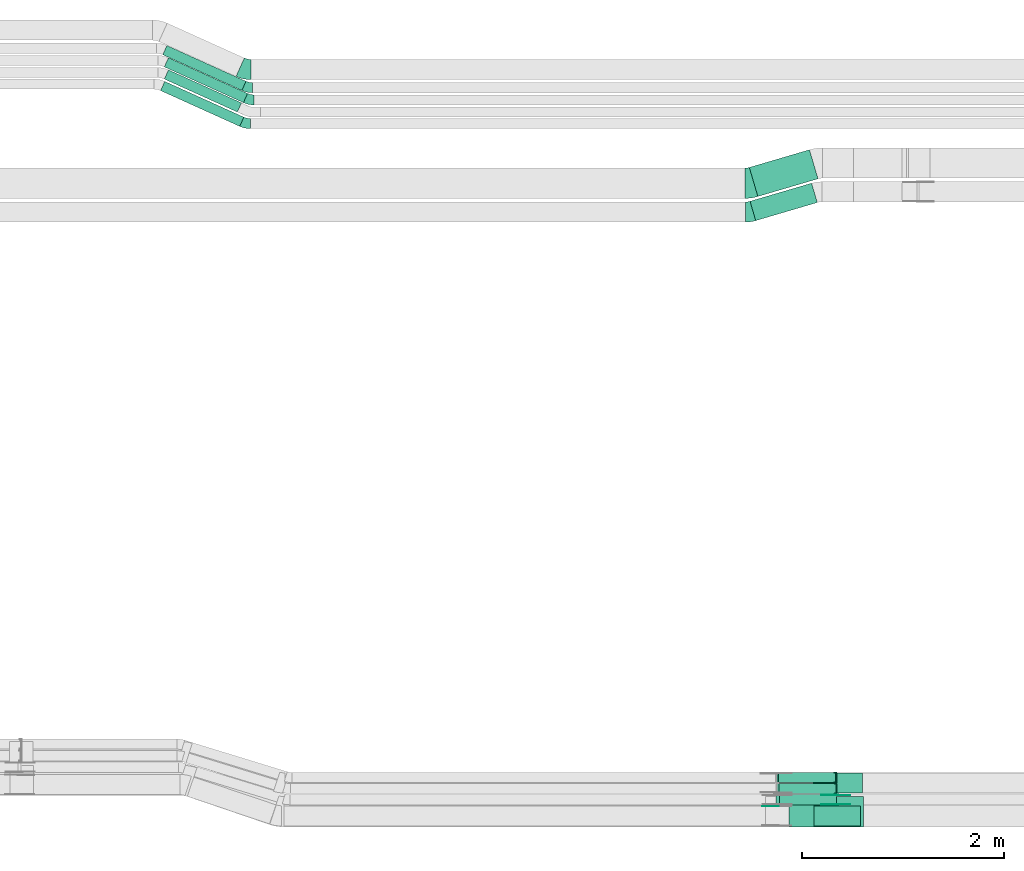
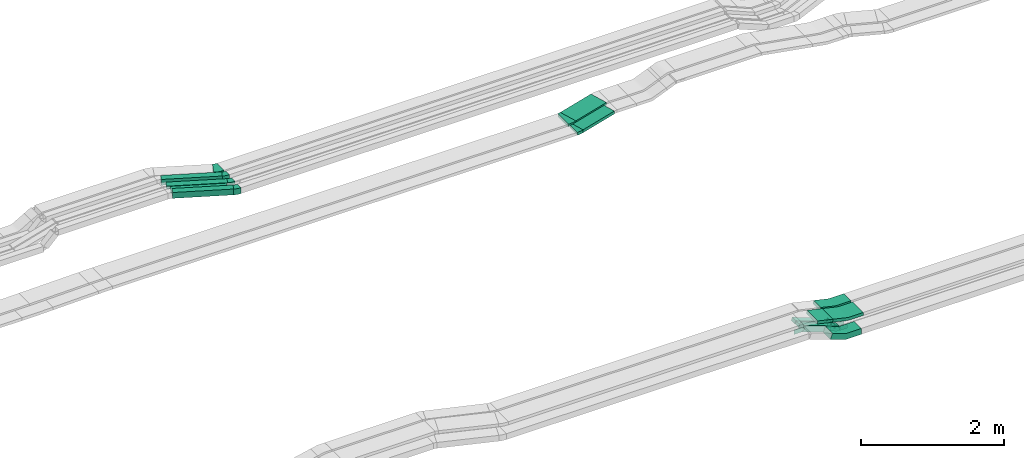
# One storey, part 13 of 28: 16 flow fittings, 10 flow segments.
"""IFC2X3 building model written with IfcOpenShell, lengths in millimetres."""

from ifc_helpers import new_model, entity, si_unit, converted_unit, derived_unit, direction, frame, frame_2d, origin, origin_2d_with_axis, place, context, subcontext, project, spatial, polyline, circle_curve, parameter, trimmed, segment, composite_curve, rectangle, outline, extrude, faceted_brep, source, transform, mapped, material, type_object, type_shapes, element, save


model = new_model("IFC2X3")

# Units and contexts
model_context = context("Model", 3, precision=0.01, world=origin(), true_north=direction((6.12303176911189e-17, 1.0)))
body_context = subcontext(model_context, "Body", "Model", "MODEL_VIEW")
ifc_project = project(units=[si_unit("LENGTHUNIT", "METRE", prefix="MILLI"), si_unit("AREAUNIT", "SQUARE_METRE"), si_unit("VOLUMEUNIT", "CUBIC_METRE"), converted_unit("PLANEANGLEUNIT", "DEGREE", entity("IfcRatioMeasure", 0.0174532925199433), si_unit("PLANEANGLEUNIT", "RADIAN"), dimensions=[0, 0, 0, 0, 0, 0, 0]), si_unit("MASSUNIT", "GRAM", prefix="KILO"), derived_unit("MASSDENSITYUNIT", [(si_unit("MASSUNIT", "GRAM", prefix="KILO"), 1), (si_unit("LENGTHUNIT", "METRE"), -3)]), derived_unit("MOMENTOFINERTIAUNIT", [(si_unit("LENGTHUNIT", "METRE"), 4)]), si_unit("TIMEUNIT", "SECOND"), si_unit("FREQUENCYUNIT", "HERTZ"), si_unit("THERMODYNAMICTEMPERATUREUNIT", "DEGREE_CELSIUS"), derived_unit("THERMALTRANSMITTANCEUNIT", [(si_unit("MASSUNIT", "GRAM", prefix="KILO"), 1), (si_unit("THERMODYNAMICTEMPERATUREUNIT", "KELVIN"), -1), (si_unit("TIMEUNIT", "SECOND"), -3)]), derived_unit("VOLUMETRICFLOWRATEUNIT", [(si_unit("LENGTHUNIT", "METRE"), 3), (si_unit("TIMEUNIT", "SECOND"), -1)]), derived_unit("MASSFLOWRATEUNIT", [(si_unit("MASSUNIT", "GRAM", prefix="KILO"), 1), (si_unit("TIMEUNIT", "SECOND"), -1)]), derived_unit("ROTATIONALFREQUENCYUNIT", [(si_unit("TIMEUNIT", "SECOND"), -1)]), si_unit("ELECTRICCURRENTUNIT", "AMPERE"), si_unit("ELECTRICVOLTAGEUNIT", "VOLT"), si_unit("POWERUNIT", "WATT"), si_unit("FORCEUNIT", "NEWTON", prefix="KILO"), si_unit("ILLUMINANCEUNIT", "LUX"), si_unit("LUMINOUSFLUXUNIT", "LUMEN"), si_unit("LUMINOUSINTENSITYUNIT", "CANDELA"), derived_unit("USERDEFINED", [(si_unit("MASSUNIT", "GRAM", prefix="KILO"), -1), (si_unit("LENGTHUNIT", "METRE"), -2), (si_unit("TIMEUNIT", "SECOND"), 3), (si_unit("LUMINOUSFLUXUNIT", "LUMEN"), 1)]), derived_unit("LINEARVELOCITYUNIT", [(si_unit("LENGTHUNIT", "METRE"), 1), (si_unit("TIMEUNIT", "SECOND"), -1)]), si_unit("PRESSUREUNIT", "PASCAL"), derived_unit("USERDEFINED", [(si_unit("LENGTHUNIT", "METRE"), -2), (si_unit("MASSUNIT", "GRAM", prefix="KILO"), 1), (si_unit("TIMEUNIT", "SECOND"), -2)]), derived_unit("LINEARFORCEUNIT", [(si_unit("MASSUNIT", "GRAM", prefix="KILO"), 1), (si_unit("LENGTHUNIT", "METRE"), 1), (si_unit("TIMEUNIT", "SECOND"), -2), (si_unit("LENGTHUNIT", "METRE"), -1)]), derived_unit("PLANARFORCEUNIT", [(si_unit("MASSUNIT", "GRAM", prefix="KILO"), 1), (si_unit("LENGTHUNIT", "METRE"), 1), (si_unit("TIMEUNIT", "SECOND"), -2), (si_unit("LENGTHUNIT", "METRE"), -2)])], contexts=[model_context])

# Site, building, storey
site_placement = place(None, origin())
site = spatial("IfcSite", under=ifc_project, at=site_placement, CompositionType="ELEMENT")
building_placement = place(site_placement, origin())
building = spatial("IfcBuilding", under=site, at=building_placement, CompositionType="ELEMENT")
storey_placement = place(building_placement, frame((0.0, 0.0, 15900.0)))
storey = spatial("IfcBuildingStorey", under=building, at=storey_placement, CompositionType="ELEMENT", Elevation=15900.0)

# Flow segments
cable_carrier_segment_type = type_object("IfcCableCarrierSegmentType", PredefinedType="CABLETRAYSEGMENT")
flow_segment_1_placement = place(storey_placement, frame((42482.32, 8215.15, 2877.21)))
element("IfcFlowSegment", 1, at=flow_segment_1_placement, inside=storey, type_object=cable_carrier_segment_type, context=body_context, shape_type="SweptSolid", body=[
    extrude(rectangle(XDim=49.9999999999981, YDim=255.770491519839, at=frame_2d((0.0, 0.0), x_axis=(0.0, 1.0))), frame((130.23, 0.0, 53.24), z_axis=(0.0, 1.0, 0.0), x_axis=(-0.974157642890838, 0.0, 0.225869180716108)), (0.0, 0.0, 1.0), 299.999999999999),
])
flow_segment_2_placement = place(storey_placement, frame((42367.7, 8434.97, 2506.48)))
element("IfcFlowSegment", 2, at=flow_segment_2_placement, inside=storey, type_object=cable_carrier_segment_type, context=body_context, shape_type="SweptSolid", body=[
    extrude(rectangle(XDim=100.000000000003, YDim=99.9999999999989, at=origin_2d_with_axis()), frame((16.92, 50.0, 250.0), z_axis=(0.940975525862782, 0.0, -0.338474607211915), x_axis=(0.338474607211915, 0.0, 0.940975525862782)), (0.0, 0.0, 1.0), 599.59714334412),
])
flow_segment_3_placement = place(storey_placement, frame((42378.69, 8544.97, 2499.72)))
element("IfcFlowSegment", 3, at=flow_segment_3_placement, inside=storey, type_object=cable_carrier_segment_type, context=body_context, shape_type="SweptSolid", body=[
    extrude(rectangle(XDim=50.0000000000049, YDim=100.000000000001, at=origin_2d_with_axis()), frame((8.68, 50.0, 232.8), z_axis=(0.937730259547007, 0.0, -0.347364304916183), x_axis=(0.347364304916183, 0.0, 0.937730259547007)), (0.0, 0.0, 1.0), 602.697848083628),
])
flow_segment_4_placement = place(storey_placement, frame((42374.95, 8654.97, 2499.69)))
element("IfcFlowSegment", 4, at=flow_segment_4_placement, inside=storey, type_object=cable_carrier_segment_type, context=body_context, shape_type="SweptSolid", body=[
    extrude(rectangle(XDim=50.0000000000049, YDim=100.000000000001, at=origin_2d_with_axis()), frame((8.68, 50.0, 232.79), z_axis=(0.937730259547007, 0.0, -0.347364304916183), x_axis=(0.347364304916183, 0.0, 0.937730259547007)), (0.0, 0.0, 1.0), 602.685608875145),
])
flow_segment_5_placement = place(storey_placement, frame((42109.48, 14214.53, 2675.0)))
element("IfcFlowSegment", 5, at=flow_segment_5_placement, inside=storey, type_object=cable_carrier_segment_type, context=body_context, shape_type="SweptSolid", body=[
    extrude(rectangle(XDim=634.797291199822, YDim=200.0, at=origin_2d_with_axis()), frame((332.72, 185.5, 0.0), z_axis=(0.0, 0.0, 1.0), x_axis=(-0.959365501571262, -0.282166323991578, 0.0)), (0.0, 0.0, 1.0), 50.0000000000016),
])
flow_segment_6_placement = place(storey_placement, frame((42102.28, 14453.59, 2675.0)))
element("IfcFlowSegment", 6, at=flow_segment_6_placement, inside=storey, type_object=cable_carrier_segment_type, context=body_context, shape_type="SweptSolid", body=[
    extrude(rectangle(XDim=620.396388266396, YDim=299.999999999998, at=origin_2d_with_axis()), frame((339.92, 231.43, 0.0), z_axis=(0.0, 0.0, 1.0), x_axis=(0.959365501571253, 0.28216632399161, 0.0)), (0.0, 0.0, 1.0), 50.0000000000016),
])
flow_segment_7_placement = place(storey_placement, frame((36298.61, 15502.59, 2835.0)))
element("IfcFlowSegment", 7, at=flow_segment_7_placement, inside=storey, type_object=cable_carrier_segment_type, context=body_context, shape_type="SweptSolid", body=[
    extrude(rectangle(XDim=858.861846645775, YDim=100.000000000002, at=origin_2d_with_axis()), frame((411.92, 222.41, 0.0), z_axis=(0.0, 0.0, 1.0), x_axis=(-0.911271304124208, 0.411806520443479, 0.0)), (0.0, 0.0, 1.0), 99.9999999999989),
])
flow_segment_8_placement = place(storey_placement, frame((36314.03, 15382.05, 2838.0)))
element("IfcFlowSegment", 8, at=flow_segment_8_placement, inside=storey, type_object=cable_carrier_segment_type, context=body_context, shape_type="SweptSolid", body=[
    extrude(rectangle(XDim=858.861846645806, YDim=100.000000000002, at=origin_2d_with_axis()), frame((411.92, 222.41, 0.0), z_axis=(0.0, 0.0, 1.0), x_axis=(-0.911271304124206, 0.411806520443484, 0.0)), (0.0, 0.0, 1.0), 50.0000000000016),
])
flow_segment_9_placement = place(storey_placement, frame((36314.03, 15289.01, 2838.0)))
element("IfcFlowSegment", 9, at=flow_segment_9_placement, inside=storey, type_object=cable_carrier_segment_type, context=body_context, shape_type="SweptSolid", body=[
    extrude(rectangle(XDim=793.388620361837, YDim=100.000000000002, at=origin_2d_with_axis()), frame((382.09, 208.92, 0.0), z_axis=(0.0, 0.0, 1.0), x_axis=(-0.911271304124207, 0.411806520443482, 0.0)), (0.0, 0.0, 1.0), 50.0000000000016),
])
flow_segment_10_placement = place(storey_placement, frame((36277.03, 15147.59, 2834.95)))
element("IfcFlowSegment", 10, at=flow_segment_10_placement, inside=storey, type_object=cable_carrier_segment_type, context=body_context, shape_type="SweptSolid", body=[
    extrude(rectangle(XDim=858.861846434138, YDim=99.9999999996995, at=origin_2d_with_axis()), frame((411.92, 222.41, 0.0), z_axis=(2.23645322951858e-06, -1.01066062150145e-06, 1.0), x_axis=(-0.911271304121465, 0.411806520442236, 2.45421228496595e-06)), (0.0, 0.0, 1.0), 99.999999999698),
])

# Flow fittings
ifc_material_1 = material()
cable_carrier_fitting_type_1 = type_object("IfcCableCarrierFittingType", PredefinedType="NOTDEFINED", material=ifc_material_1)
shared_shape_1 = source(origin(), body_context, "Body", "Brep", [
    faceted_brep([(-8.96, 25.0, 50.0), (-8.96, 25.0, -50.0), (-8.96, -25.0, -50.0), (-8.96, -25.0, -47.46), (-8.96, 22.46, -47.46), (-8.96, 22.46, 47.46), (-8.96, -25.0, 47.46), (-8.96, -25.0, 50.0), (-0.28, 26.56, 50.0), (17.09, -20.33, 50.0), (17.09, -20.33, 47.46), (0.6, 24.17, 47.46), (0.6, 24.17, -47.46), (17.09, -20.33, -47.46), (17.09, -20.33, -50.0), (-0.28, 26.56, -50.0), (-4.48, 25.0, 50.0), (-4.48, 25.0, -50.0), (4.48, -25.0, -50.0), (4.48, -25.0, -47.46), (-4.03, 22.46, -47.46), (-4.03, 22.46, 47.46), (4.48, -25.0, 47.46), (4.48, -25.0, 50.0)], [[[0, 1, 2, 3, 4, 5, 6, 7]], [[8, 9, 10, 11, 12, 13, 14, 15]], [[1, 0, 16, 17]], [[2, 1, 17, 15, 14, 18]], [[3, 2, 18, 19]], [[4, 3, 19, 13, 12, 20]], [[5, 4, 20, 21]], [[6, 5, 21, 11, 10, 22]], [[7, 6, 22, 23]], [[0, 7, 23, 9, 8, 16]], [[17, 16, 8, 15]], [[19, 18, 14, 13]], [[21, 20, 12, 11]], [[23, 22, 10, 9]]]),
])
type_shapes(cable_carrier_fitting_type_1, [shared_shape_1])
for number, where, z_axis, x_axis in (
    (11, (42960.95, 8594.97, 2520.05), (0.0, -1.0, 0.0), (0.937730259547021, 0.0, -0.347364304916146)),
    (12, (42957.2, 8704.97, 2520.02), (0.0, -1.0, 0.0), (0.937730259547021, 0.0, -0.347364304916146)),
):
    element("IfcFlowFitting", number, at=place(storey_placement, frame(where, z_axis=z_axis, x_axis=x_axis)), inside=storey, type_object=cable_carrier_fitting_type_1, material=ifc_material_1, context=body_context, shape_type="MappedRepresentation", body=[
        mapped(shared_shape_1, transform((0.0, 0.0, 0.0), scale=1.0)),
    ])
cable_carrier_fitting_type_2 = type_object("IfcCableCarrierFittingType", Name="470_DKC_S5_CS 90 internal vertical angle:-", PredefinedType="NOTDEFINED", material=ifc_material_1)
shared_shape_2 = source(origin(), body_context, "Body", "SweptSolid", [
    extrude(outline(composite_curve([segment(polyline([(-248.69, -40.04), (-14.3, -40.04)]), True, "CONTINUOUS"), segment(trimmed(circle_curve(frame_2d((-14.3, 124.96), x_axis=(0.0, -1.0)), 164.999999999999), [parameter(0.0)], [parameter(13.0539943692735)], True, "PARAMETER"), True, "CONTINUOUS"), segment(polyline([(22.97, -35.78), (251.31, 17.16)]), True, "CONTINUOUS"), segment(polyline([(251.31, 17.16), (240.02, 65.87)]), True, "CONTINUOUS"), segment(polyline([(240.02, 65.87), (11.68, 12.93)]), True, "CONTINUOUS"), segment(trimmed(circle_curve(frame_2d((-14.3, 124.96), x_axis=(0.0, -1.0)), 114.999999999999), [parameter(0.0)], [parameter(13.0539943692735)], True, "PARAMETER"), False, "CONTINUOUS"), segment(polyline([(-14.3, 9.96), (-248.69, 9.96)]), True, "CONTINUOUS"), segment(polyline([(-248.69, 9.96), (-248.69, -40.04)]), True, "CONTINUOUS")], self_intersect=False)), frame((-1.72, 15.04, -150.0)), (0.0, 0.0, 1.0), 300.0),
])
type_shapes(cable_carrier_fitting_type_2, [shared_shape_2])
flow_fitting_1_placement = place(storey_placement, frame((42981.07, 8365.15, 2845.0), z_axis=(0.0, 1.0, 0.0), x_axis=(-1.0, 0.0, 0.0)))
element("IfcFlowFitting", 13, at=flow_fitting_1_placement, inside=storey, type_object=cable_carrier_fitting_type_2, material=ifc_material_1, Name="470_DKC_S5_CS 90 internal vertical angle:-", ObjectType="470_DKC_S5_CS 90 internal vertical angle:-", context=body_context, shape_type="MappedRepresentation", body=[
    mapped(shared_shape_2, transform((0.0, 0.0, 0.0), scale=1.0)),
])
cable_carrier_fitting_type_3 = type_object("IfcCableCarrierFittingType", Name="470_DKC_S5_CS 90 internal vertical angle:-", PredefinedType="NOTDEFINED", material=ifc_material_1)
shared_shape_3 = source(origin(), body_context, "Body", "SweptSolid", [
    extrude(outline(composite_curve([segment(polyline([(-248.69, -40.04), (-14.3, -40.04)]), True, "CONTINUOUS"), segment(trimmed(circle_curve(frame_2d((-14.3, 124.96), x_axis=(0.0, -1.0)), 164.999999999999), [parameter(0.0)], [parameter(13.0539943692735)], True, "PARAMETER"), True, "CONTINUOUS"), segment(polyline([(22.97, -35.78), (251.31, 17.16)]), True, "CONTINUOUS"), segment(polyline([(251.31, 17.16), (240.02, 65.87)]), True, "CONTINUOUS"), segment(polyline([(240.02, 65.87), (11.68, 12.93)]), True, "CONTINUOUS"), segment(trimmed(circle_curve(frame_2d((-14.3, 124.96), x_axis=(0.0, -1.0)), 114.999999999999), [parameter(0.0)], [parameter(13.0539943692735)], True, "PARAMETER"), False, "CONTINUOUS"), segment(polyline([(-14.3, 9.96), (-248.69, 9.96)]), True, "CONTINUOUS"), segment(polyline([(-248.69, 9.96), (-248.69, -40.04)]), True, "CONTINUOUS")], self_intersect=False)), frame((-1.72, 15.04, -100.0)), (0.0, 0.0, 1.0), 200.0),
])
type_shapes(cable_carrier_fitting_type_3, [shared_shape_3])
flow_fitting_2_placement = place(storey_placement, frame((42971.26, 8650.15, 2845.0), z_axis=(0.0, 1.0, 0.0), x_axis=(-1.0, 0.0, 0.0)))
element("IfcFlowFitting", 14, at=flow_fitting_2_placement, inside=storey, type_object=cable_carrier_fitting_type_3, material=ifc_material_1, Name="470_DKC_S5_CS 90 internal vertical angle:-", ObjectType="470_DKC_S5_CS 90 internal vertical angle:-", context=body_context, shape_type="MappedRepresentation", body=[
    mapped(shared_shape_3, transform((0.0, 0.0, 0.0), scale=1.0)),
])
cable_carrier_fitting_type_4 = type_object("IfcCableCarrierFittingType", Name="470_DKC_S5_CS 90 internal vertical angle:-", PredefinedType="NOTDEFINED", material=ifc_material_1)
shared_shape_4 = source(origin(), body_context, "Body", "SweptSolid", [
    extrude(outline(composite_curve([segment(polyline([(-244.79, -73.49), (-24.68, -73.49)]), True, "CONTINUOUS"), segment(trimmed(circle_curve(frame_2d((-24.68, 141.51), x_axis=(0.0, -1.0)), 214.999999999999), [parameter(0.0)], [parameter(19.7839661238225)], True, "PARAMETER"), True, "CONTINUOUS"), segment(polyline([(48.1, -60.8), (255.21, 13.7)]), True, "CONTINUOUS"), segment(polyline([(255.21, 13.7), (221.37, 107.79)]), True, "CONTINUOUS"), segment(polyline([(221.37, 107.79), (14.25, 33.29)]), True, "CONTINUOUS"), segment(trimmed(circle_curve(frame_2d((-24.68, 141.51), x_axis=(0.0, -1.0)), 114.999999999999), [parameter(0.0)], [parameter(19.7839661238225)], True, "PARAMETER"), False, "CONTINUOUS"), segment(polyline([(-24.68, 26.51), (-244.79, 26.51)]), True, "CONTINUOUS"), segment(polyline([(-244.79, 26.51), (-244.79, -73.49)]), True, "CONTINUOUS")], self_intersect=False)), frame((-4.1, 23.49, -100.0)), (0.0, 0.0, 1.0), 200.0),
])
type_shapes(cable_carrier_fitting_type_4, [shared_shape_4])
flow_fitting_3_placement = place(storey_placement, frame((42954.58, 8324.97, 2550.0), z_axis=(0.0, -1.0, 0.0), x_axis=(0.940975525862787, 0.0, -0.338474607211903)))
element("IfcFlowFitting", 15, at=flow_fitting_3_placement, inside=storey, type_object=cable_carrier_fitting_type_4, material=ifc_material_1, Name="470_DKC_S5_CS 90 internal vertical angle:-", ObjectType="470_DKC_S5_CS 90 internal vertical angle:-", context=body_context, shape_type="MappedRepresentation", body=[
    mapped(shared_shape_4, transform((0.0, 0.0, 0.0), scale=1.0)),
])
ifc_material_2 = material(Name="G")
cable_carrier_fitting_type_5 = type_object("IfcCableCarrierFittingType", PredefinedType="NOTDEFINED", material=ifc_material_2)
shared_shape_5 = source(origin(), body_context, "Body", "SweptSolid", [
    extrude(outline(composite_curve([segment(trimmed(circle_curve(frame_2d((-41.47, 0.0), x_axis=(1.0, 0.0)), 25.0), [parameter(90.0000000000007)], [parameter(270.0)], True, "PARAMETER"), True, "CONTINUOUS"), segment(polyline([(-41.47, -25.0), (-29.97, -25.0)]), True, "CONTINUOUS"), segment(polyline([(-29.97, -25.0), (-28.1, -38.5)]), True, "CONTINUOUS"), segment(polyline([(-28.1, -38.5), (99.53, -38.5)]), True, "CONTINUOUS"), segment(polyline([(99.53, -38.5), (99.53, 38.5)]), True, "CONTINUOUS"), segment(polyline([(99.53, 38.5), (-28.1, 38.5)]), True, "CONTINUOUS"), segment(polyline([(-28.1, 38.5), (-29.97, 25.0)]), True, "CONTINUOUS"), segment(polyline([(-29.97, 25.0), (-41.47, 25.0)]), True, "CONTINUOUS")], self_intersect=False)), frame((41.47, 0.0, 0.0), z_axis=(0.0, 0.0, -1.0), x_axis=(1.0, 0.0, 0.0)), (0.0, 0.0, -1.0), 2.0),
])
type_shapes(cable_carrier_fitting_type_5, [shared_shape_5])
flow_fitting_4_placement = place(storey_placement, frame((42958.63, 8530.43, 2550.0), z_axis=(0.0, 1.0, 0.0), x_axis=(-0.940975525862779, 0.0, 0.338474607211925)))
element("IfcFlowFitting", 16, at=flow_fitting_4_placement, inside=storey, type_object=cable_carrier_fitting_type_5, material=ifc_material_2, context=body_context, shape_type="MappedRepresentation", body=[
    mapped(shared_shape_5, transform((0.0, 0.0, 0.0), scale=1.0)),
])
cable_carrier_fitting_type_6 = type_object("IfcCableCarrierFittingType", PredefinedType="NOTDEFINED", material=ifc_material_2)
type_shapes(cable_carrier_fitting_type_6, [shared_shape_5])
flow_fitting_5_placement = place(storey_placement, frame((42958.63, 8441.51, 2550.0), z_axis=(0.0, -1.0, 0.0), x_axis=(1.0, 0.0, 0.0)))
element("IfcFlowFitting", 17, at=flow_fitting_5_placement, inside=storey, type_object=cable_carrier_fitting_type_6, material=ifc_material_2, context=body_context, shape_type="MappedRepresentation", body=[
    mapped(shared_shape_5, transform((0.0, 0.0, 0.0), scale=1.0)),
])
cable_carrier_fitting_type_7 = type_object("IfcCableCarrierFittingType", PredefinedType="NOTDEFINED", material=ifc_material_2)
shared_shape_6 = source(origin(), body_context, "Body", "SweptSolid", [
    extrude(outline(composite_curve([segment(trimmed(circle_curve(frame_2d((-41.47, 0.0), x_axis=(1.0, 0.0)), 25.0), [parameter(90.0000000000007)], [parameter(270.0)], True, "PARAMETER"), True, "CONTINUOUS"), segment(polyline([(-41.47, -25.0), (-29.97, -25.0)]), True, "CONTINUOUS"), segment(polyline([(-29.97, -25.0), (-28.1, -38.5)]), True, "CONTINUOUS"), segment(polyline([(-28.1, -38.5), (99.53, -38.5)]), True, "CONTINUOUS"), segment(polyline([(99.53, -38.5), (99.53, 38.5)]), True, "CONTINUOUS"), segment(polyline([(99.53, 38.5), (-28.1, 38.5)]), True, "CONTINUOUS"), segment(polyline([(-28.1, 38.5), (-29.97, 25.0)]), True, "CONTINUOUS"), segment(polyline([(-29.97, 25.0), (-41.47, 25.0)]), True, "CONTINUOUS")], self_intersect=False)), frame((41.47, 0.0, 0.0)), (0.0, 0.0, 1.0), 2.0),
])
type_shapes(cable_carrier_fitting_type_7, [shared_shape_6])
flow_fitting_6_placement = place(storey_placement, frame((42958.63, 8439.51, 2550.0), z_axis=(0.0, -1.0, 0.0), x_axis=(-0.940975525862779, 0.0, 0.338474607211925)))
element("IfcFlowFitting", 18, at=flow_fitting_6_placement, inside=storey, type_object=cable_carrier_fitting_type_7, material=ifc_material_2, context=body_context, shape_type="MappedRepresentation", body=[
    mapped(shared_shape_6, transform((0.0, 0.0, 0.0), scale=1.0)),
])
cable_carrier_fitting_type_8 = type_object("IfcCableCarrierFittingType", PredefinedType="NOTDEFINED", material=ifc_material_2)
type_shapes(cable_carrier_fitting_type_8, [shared_shape_6])
for number, where, z_axis, x_axis in (
    (19, (42958.63, 8528.43, 2550.0), (0.0, 1.0, 0.0), (1.0, 0.0, 0.0)),
    (20, (42370.77, 8418.43, 2760.0), (0.0, 1.0, 0.0), (-1.0, 0.0, 0.0)),
):
    element("IfcFlowFitting", number, at=place(storey_placement, frame(where, z_axis=z_axis, x_axis=x_axis)), inside=storey, type_object=cable_carrier_fitting_type_8, material=ifc_material_2, context=body_context, shape_type="MappedRepresentation", body=[
        mapped(shared_shape_6, transform((0.0, 0.0, 0.0), scale=1.0)),
    ])
cable_carrier_fitting_type_9 = type_object("IfcCableCarrierFittingType", Name="470_DKC_S5_Variable Angle Elbow 0-45:-", PredefinedType="NOTDEFINED", material=ifc_material_1)
shared_shape_7 = source(origin(), body_context, "Body", "SweptSolid", [
    extrude(outline(composite_curve([segment(polyline([(-36.26, -105.15), (-35.26, -105.15)]), True, "CONTINUOUS"), segment(trimmed(circle_curve(frame_2d((-35.26, 244.85), x_axis=(0.0, -1.0)), 350.0), [parameter(0.0)], [parameter(16.3895403340349)], True, "PARAMETER"), True, "CONTINUOUS"), segment(polyline([(63.5, -90.93), (64.46, -90.65)]), True, "CONTINUOUS"), segment(polyline([(64.46, -90.65), (8.02, 101.23)]), True, "CONTINUOUS"), segment(polyline([(8.02, 101.23), (7.06, 100.95)]), True, "CONTINUOUS"), segment(trimmed(circle_curve(frame_2d((-35.26, 244.85), x_axis=(0.0, -1.0)), 150.0), [parameter(0.0)], [parameter(16.3895403340349)], True, "PARAMETER"), False, "CONTINUOUS"), segment(polyline([(-35.26, 94.85), (-36.26, 94.85)]), True, "CONTINUOUS"), segment(polyline([(-36.26, 94.85), (-36.26, -105.15)]), True, "CONTINUOUS")], self_intersect=False)), frame((-0.74, 5.15, -25.0)), (0.0, 0.0, 1.0), 50.0000000000005),
])
type_shapes(cable_carrier_fitting_type_9, [shared_shape_7])
flow_fitting_7_placement = place(storey_placement, frame((42102.19, 14300.03, 2700.0)))
element("IfcFlowFitting", 21, at=flow_fitting_7_placement, inside=storey, type_object=cable_carrier_fitting_type_9, material=ifc_material_1, Name="470_DKC_S5_Variable Angle Elbow 0-45:-", ObjectType="470_DKC_S5_Variable Angle Elbow 0-45:-", context=body_context, shape_type="MappedRepresentation", body=[
    mapped(shared_shape_7, transform((0.0, 0.0, 0.0), scale=1.0)),
])
cable_carrier_fitting_type_10 = type_object("IfcCableCarrierFittingType", Name="470_DKC_S5_Variable Angle Elbow 0-45:-", PredefinedType="NOTDEFINED", material=ifc_material_1)
shared_shape_8 = source(origin(), body_context, "Body", "SweptSolid", [
    extrude(outline(composite_curve([segment(polyline([(-43.31, -156.17), (-42.31, -156.17)]), True, "CONTINUOUS"), segment(trimmed(circle_curve(frame_2d((-42.31, 293.83), x_axis=(0.0, -1.0)), 450.0), [parameter(0.0)], [parameter(16.3895403340363)], True, "PARAMETER"), True, "CONTINUOUS"), segment(polyline([(84.66, -137.88), (85.62, -137.6)]), True, "CONTINUOUS"), segment(polyline([(85.62, -137.6), (0.97, 150.21)]), True, "CONTINUOUS"), segment(polyline([(0.97, 150.21), (0.01, 149.93)]), True, "CONTINUOUS"), segment(trimmed(circle_curve(frame_2d((-42.31, 293.83), x_axis=(0.0, -1.0)), 150.0), [parameter(0.0)], [parameter(16.3895403340363)], True, "PARAMETER"), False, "CONTINUOUS"), segment(polyline([(-42.31, 143.83), (-43.31, 143.83)]), True, "CONTINUOUS"), segment(polyline([(-43.31, 143.83), (-43.31, -156.17)]), True, "CONTINUOUS")], self_intersect=False)), frame((-0.89, 6.17, -25.0)), (0.0, 0.0, 1.0), 49.9999999999995),
])
type_shapes(cable_carrier_fitting_type_10, [shared_shape_8])
flow_fitting_8_placement = place(storey_placement, frame((42102.19, 14585.03, 2700.0)))
element("IfcFlowFitting", 22, at=flow_fitting_8_placement, inside=storey, type_object=cable_carrier_fitting_type_10, material=ifc_material_1, Name="470_DKC_S5_Variable Angle Elbow 0-45:-", ObjectType="470_DKC_S5_Variable Angle Elbow 0-45:-", context=body_context, shape_type="MappedRepresentation", body=[
    mapped(shared_shape_8, transform((0.0, 0.0, 0.0), scale=1.0)),
])
cable_carrier_fitting_type_11 = type_object("IfcCableCarrierFittingType", Name="470_DKC_S5_Variable Angle Elbow 0-45:-", PredefinedType="NOTDEFINED", material=ifc_material_1)
shared_shape_9 = source(origin(), body_context, "Body", "SweptSolid", [
    extrude(outline(composite_curve([segment(polyline([(-52.45, -111.19), (-51.45, -111.19)]), True, "CONTINUOUS"), segment(trimmed(circle_curve(frame_2d((-51.45, 238.81), x_axis=(0.0, -1.0)), 350.0), [parameter(0.0)], [parameter(24.3183682159225)], True, "PARAMETER"), True, "CONTINUOUS"), segment(polyline([(92.68, -80.14), (93.59, -79.73)]), True, "CONTINUOUS"), segment(polyline([(93.59, -79.73), (11.23, 102.53)]), True, "CONTINUOUS"), segment(polyline([(11.23, 102.53), (10.32, 102.12)]), True, "CONTINUOUS"), segment(trimmed(circle_curve(frame_2d((-51.45, 238.81), x_axis=(0.0, -1.0)), 150.0), [parameter(0.0)], [parameter(24.3183682159225)], True, "PARAMETER"), False, "CONTINUOUS"), segment(polyline([(-51.45, 88.81), (-52.45, 88.81)]), True, "CONTINUOUS"), segment(polyline([(-52.45, 88.81), (-52.45, -111.19)]), True, "CONTINUOUS")], self_intersect=False)), frame((-2.41, 11.19, -50.0)), (0.0, 0.0, 1.0), 100.0),
])
type_shapes(cable_carrier_fitting_type_11, [shared_shape_9])
flow_fitting_9_placement = place(storey_placement, frame((37114.6, 15709.99, 2885.0), z_axis=(0.0, 0.0, 1.0), x_axis=(0.911271304124217, -0.411806520443459, 0.0)))
element("IfcFlowFitting", 23, at=flow_fitting_9_placement, inside=storey, type_object=cable_carrier_fitting_type_11, material=ifc_material_1, Name="470_DKC_S5_Variable Angle Elbow 0-45:-", ObjectType="470_DKC_S5_Variable Angle Elbow 0-45:-", context=body_context, shape_type="MappedRepresentation", body=[
    mapped(shared_shape_9, transform((0.0, 0.0, 0.0), scale=1.0)),
])
cable_carrier_fitting_type_12 = type_object("IfcCableCarrierFittingType", Name="470_DKC_S5_Variable Angle Elbow 0-45:-", PredefinedType="NOTDEFINED", material=ifc_material_1)
shared_shape_10 = source(origin(), body_context, "Body", "SweptSolid", [
    extrude(outline(composite_curve([segment(polyline([(-42.16, -58.98), (-41.16, -58.98)]), True, "CONTINUOUS"), segment(trimmed(circle_curve(frame_2d((-41.16, 191.02), x_axis=(0.0, -1.0)), 250.0), [parameter(0.0)], [parameter(24.3183682159238)], True, "PARAMETER"), True, "CONTINUOUS"), segment(polyline([(61.79, -36.79), (62.7, -36.38)]), True, "CONTINUOUS"), segment(polyline([(62.7, -36.38), (21.52, 54.75)]), True, "CONTINUOUS"), segment(polyline([(21.52, 54.75), (20.61, 54.33)]), True, "CONTINUOUS"), segment(trimmed(circle_curve(frame_2d((-41.16, 191.02), x_axis=(0.0, -1.0)), 150.0), [parameter(0.0)], [parameter(24.3183682159238)], True, "PARAMETER"), False, "CONTINUOUS"), segment(polyline([(-41.16, 41.02), (-42.16, 41.02)]), True, "CONTINUOUS"), segment(polyline([(-42.16, 41.02), (-42.16, -58.98)]), True, "CONTINUOUS")], self_intersect=False)), frame((-1.93, 8.98, -50.0)), (0.0, 0.0, 1.0), 100.0),
])
type_shapes(cable_carrier_fitting_type_12, [shared_shape_10])
flow_fitting_10_placement = place(storey_placement, frame((37142.03, 15529.99, 2885.0), z_axis=(0.0, 0.0, 1.0), x_axis=(0.911271304124212, -0.41180652044347, 0.0)))
element("IfcFlowFitting", 24, at=flow_fitting_10_placement, inside=storey, type_object=cable_carrier_fitting_type_12, material=ifc_material_1, Name="470_DKC_S5_Variable Angle Elbow 0-45:-", ObjectType="470_DKC_S5_Variable Angle Elbow 0-45:-", context=body_context, shape_type="MappedRepresentation", body=[
    mapped(shared_shape_10, transform((0.0, 0.0, 0.0), scale=1.0)),
])
cable_carrier_fitting_type_13 = type_object("IfcCableCarrierFittingType", Name="470_DKC_S5_Variable Angle Elbow 0-45:-", PredefinedType="NOTDEFINED", material=ifc_material_1)
shared_shape_11 = source(origin(), body_context, "Body", "SweptSolid", [
    extrude(outline(composite_curve([segment(polyline([(-42.16, -58.98), (-41.16, -58.98)]), True, "CONTINUOUS"), segment(trimmed(circle_curve(frame_2d((-41.16, 191.02), x_axis=(0.0, -1.0)), 250.0), [parameter(0.0)], [parameter(24.3183682159238)], True, "PARAMETER"), True, "CONTINUOUS"), segment(polyline([(61.79, -36.79), (62.7, -36.38)]), True, "CONTINUOUS"), segment(polyline([(62.7, -36.38), (21.52, 54.75)]), True, "CONTINUOUS"), segment(polyline([(21.52, 54.75), (20.61, 54.33)]), True, "CONTINUOUS"), segment(trimmed(circle_curve(frame_2d((-41.16, 191.02), x_axis=(0.0, -1.0)), 150.0), [parameter(0.0)], [parameter(24.3183682159238)], True, "PARAMETER"), False, "CONTINUOUS"), segment(polyline([(-41.16, 41.02), (-42.16, 41.02)]), True, "CONTINUOUS"), segment(polyline([(-42.16, 41.02), (-42.16, -58.98)]), True, "CONTINUOUS")], self_intersect=False)), frame((-1.93, 8.98, -25.0)), (0.0, 0.0, 1.0), 50.0),
])
type_shapes(cable_carrier_fitting_type_13, [shared_shape_11])
flow_fitting_11_placement = place(storey_placement, frame((37157.45, 15409.46, 2863.0), z_axis=(0.0, 0.0, 1.0), x_axis=(0.911271304124212, -0.41180652044347, 0.0)))
element("IfcFlowFitting", 25, at=flow_fitting_11_placement, inside=storey, type_object=cable_carrier_fitting_type_13, material=ifc_material_1, Name="470_DKC_S5_Variable Angle Elbow 0-45:-", ObjectType="470_DKC_S5_Variable Angle Elbow 0-45:-", context=body_context, shape_type="MappedRepresentation", body=[
    mapped(shared_shape_11, transform((0.0, 0.0, 0.0), scale=1.0)),
])
cable_carrier_fitting_type_14 = type_object("IfcCableCarrierFittingType", Name="470_DKC_S5_Variable Angle Elbow 0-45:-", PredefinedType="NOTDEFINED", material=ifc_material_1)
shared_shape_12 = source(origin(), body_context, "Body", "SweptSolid", [
    extrude(outline(composite_curve([segment(polyline([(-42.16, -58.98), (-41.16, -58.98)]), True, "CONTINUOUS"), segment(trimmed(circle_curve(frame_2d((-41.16, 191.02), x_axis=(0.0, -1.0)), 250.0), [parameter(0.0)], [parameter(24.3183683607981)], True, "PARAMETER"), True, "CONTINUOUS"), segment(polyline([(61.79, -36.79), (62.7, -36.38)]), True, "CONTINUOUS"), segment(polyline([(62.7, -36.38), (21.52, 54.75)]), True, "CONTINUOUS"), segment(polyline([(21.52, 54.75), (20.61, 54.33)]), True, "CONTINUOUS"), segment(trimmed(circle_curve(frame_2d((-41.16, 191.02), x_axis=(0.0, -1.0)), 150.0), [parameter(0.0)], [parameter(24.3183683607981)], True, "PARAMETER"), False, "CONTINUOUS"), segment(polyline([(-41.16, 41.02), (-42.16, 41.02)]), True, "CONTINUOUS"), segment(polyline([(-42.16, 41.02), (-42.16, -58.98)]), True, "CONTINUOUS")], self_intersect=False)), frame((-1.93, 8.98, -50.0)), (0.0, 0.0, 1.0), 100.0),
])
type_shapes(cable_carrier_fitting_type_14, [shared_shape_12])
flow_fitting_12_placement = place(storey_placement, frame((37120.46, 15174.99, 2884.96), z_axis=(0.0, 0.000116085582501322, 0.999999993262069), x_axis=(0.911271303082948, -0.411806519972919, 4.78048000710039e-05)))
element("IfcFlowFitting", 26, at=flow_fitting_12_placement, inside=storey, type_object=cable_carrier_fitting_type_14, material=ifc_material_1, Name="470_DKC_S5_Variable Angle Elbow 0-45:-", ObjectType="470_DKC_S5_Variable Angle Elbow 0-45:-", context=body_context, shape_type="MappedRepresentation", body=[
    mapped(shared_shape_12, transform((0.0, 0.0, 0.0), scale=1.0)),
])

save(model, "model.ifc")
